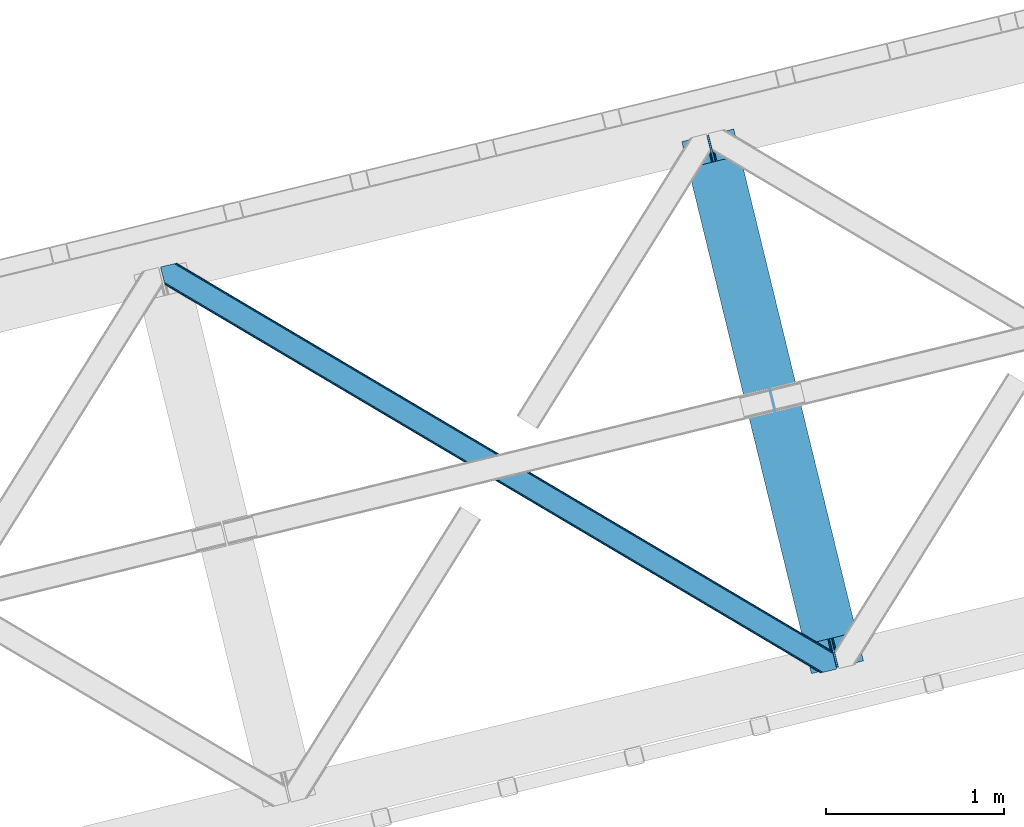
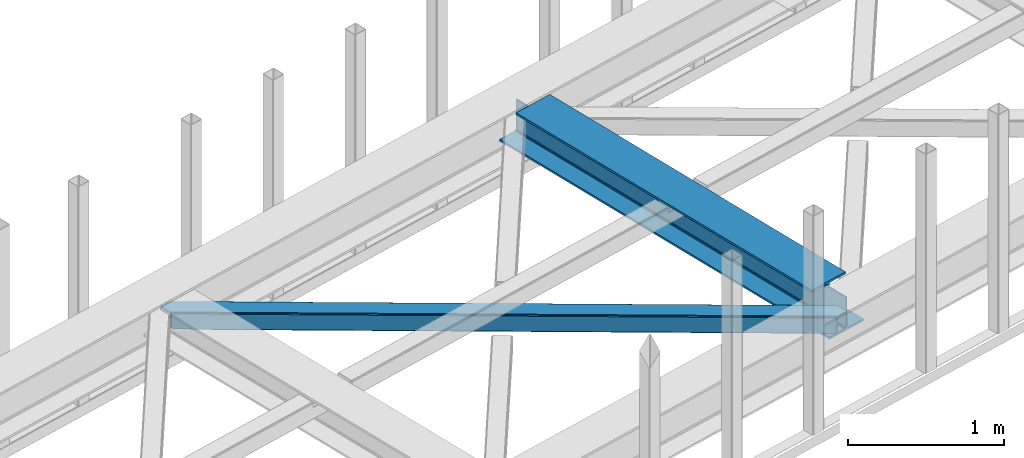
# One storey, part 41 of 66: 1 beam, 1 member.
"""IFC4 building model written with IfcOpenShell, lengths in millimetres."""

from ifc_helpers import new_model, entity, si_unit, converted_unit, derived_unit, direction, frame, origin, place, context, subcontext, project, spatial, triangles, polygons, material, type_object, element, save


model = new_model("IFC4")

# Units and contexts
model_context = context("Model", 3, precision=0.01, world=origin(), true_north=direction((6.12303176911189e-17, 1.0)))
plan_context = context("Plan", 3, precision=0.01, world=origin(), true_north=direction((6.12303176911189e-17, 1.0)))
body_context = subcontext(model_context, "Body", "Model", "MODEL_VIEW")
ifc_project = project(units=[si_unit("LENGTHUNIT", "METRE", prefix="MILLI"), si_unit("AREAUNIT", "SQUARE_METRE"), si_unit("VOLUMEUNIT", "CUBIC_METRE"), converted_unit("PLANEANGLEUNIT", "DEGREE", entity("IfcRatioMeasure", 0.0174532925199433), si_unit("PLANEANGLEUNIT", "RADIAN"), dimensions=[0, 0, 0, 0, 0, 0, 0]), si_unit("MASSUNIT", "GRAM", prefix="KILO"), derived_unit("MASSDENSITYUNIT", [(si_unit("MASSUNIT", "GRAM", prefix="KILO"), 1), (si_unit("LENGTHUNIT", "METRE"), -3)]), derived_unit("MOMENTOFINERTIAUNIT", [(si_unit("LENGTHUNIT", "METRE"), 4)]), si_unit("TIMEUNIT", "SECOND"), si_unit("FREQUENCYUNIT", "HERTZ"), si_unit("THERMODYNAMICTEMPERATUREUNIT", "DEGREE_CELSIUS"), derived_unit("THERMALTRANSMITTANCEUNIT", [(si_unit("MASSUNIT", "GRAM", prefix="KILO"), 1), (si_unit("THERMODYNAMICTEMPERATUREUNIT", "KELVIN"), -1), (si_unit("TIMEUNIT", "SECOND"), -3)]), derived_unit("VOLUMETRICFLOWRATEUNIT", [(si_unit("LENGTHUNIT", "METRE"), 3), (si_unit("TIMEUNIT", "SECOND"), -1)]), derived_unit("MASSFLOWRATEUNIT", [(si_unit("MASSUNIT", "GRAM", prefix="KILO"), 1), (si_unit("TIMEUNIT", "SECOND"), -1)]), derived_unit("ROTATIONALFREQUENCYUNIT", [(si_unit("TIMEUNIT", "SECOND"), -1)]), si_unit("ELECTRICCURRENTUNIT", "AMPERE"), si_unit("ELECTRICVOLTAGEUNIT", "VOLT"), si_unit("POWERUNIT", "WATT"), si_unit("FORCEUNIT", "NEWTON", prefix="KILO"), si_unit("ILLUMINANCEUNIT", "LUX"), si_unit("LUMINOUSFLUXUNIT", "LUMEN"), si_unit("LUMINOUSINTENSITYUNIT", "CANDELA"), derived_unit("USERDEFINED", [(si_unit("MASSUNIT", "GRAM", prefix="KILO"), -1), (si_unit("LENGTHUNIT", "METRE"), -2), (si_unit("TIMEUNIT", "SECOND"), 3), (si_unit("LUMINOUSFLUXUNIT", "LUMEN"), 1)]), derived_unit("LINEARVELOCITYUNIT", [(si_unit("LENGTHUNIT", "METRE"), 1), (si_unit("TIMEUNIT", "SECOND"), -1)]), si_unit("PRESSUREUNIT", "PASCAL"), derived_unit("USERDEFINED", [(si_unit("LENGTHUNIT", "METRE"), -2), (si_unit("MASSUNIT", "GRAM", prefix="KILO"), 1), (si_unit("TIMEUNIT", "SECOND"), -2)]), derived_unit("LINEARFORCEUNIT", [(si_unit("MASSUNIT", "GRAM", prefix="KILO"), 1), (si_unit("LENGTHUNIT", "METRE"), 1), (si_unit("TIMEUNIT", "SECOND"), -2), (si_unit("LENGTHUNIT", "METRE"), -1)]), derived_unit("PLANARFORCEUNIT", [(si_unit("MASSUNIT", "GRAM", prefix="KILO"), 1), (si_unit("LENGTHUNIT", "METRE"), 1), (si_unit("TIMEUNIT", "SECOND"), -2), (si_unit("LENGTHUNIT", "METRE"), -2)])], contexts=[model_context, plan_context])

# Site, building, storey
site_placement = place(None, origin())
site = spatial("IfcSite", under=ifc_project, at=site_placement, CompositionType="ELEMENT")
building_placement = place(site_placement, origin())
building = spatial("IfcBuilding", under=site, at=building_placement, CompositionType="ELEMENT")
storey_placement = place(building_placement, frame((0.0, 0.0, 19800.0)))
storey = spatial("IfcBuildingStorey", under=building, at=storey_placement, Name="06", CompositionType="ELEMENT", Elevation=19800.0)

# Beam
ifc_material = material(Name="Metal painted (White)")
beam_type = type_object("IfcBeamType", PredefinedType="BEAM")
beam_placement = place(storey_placement, frame((-24164.82, 11904.5, 3807.02)))
element("IfcBeam", 1, at=beam_placement, inside=storey, type_object=beam_type, material=ifc_material, ObjectType="Steel Beam", PredefinedType="BEAM", context=body_context, shape_type="Tessellation", body=[
    polygons([(1018.16648378329, 71.0478278971021, 15.5000000000008), (1018.16648378329, 71.0478278971, 0.0), (291.465617442446, 3052.25531830421, 0.0), (291.465617442446, 3052.25531830421, 15.5000000000008), (894.779372399325, 40.970914087327, 15.5000000000008), (168.078506058478, 3022.17840449444, 15.5000000000008), (888.087028625371, 39.3395844888221, 16.8701684147984), (161.38616228452, 3020.54707489593, 16.8701684147984), (882.413533524746, 37.9566100336519, 20.7720779386478), (155.712667183895, 3019.16410044076, 20.7720779386478), (878.622625296176, 37.0325360459184, 26.6116982174338), (151.921758955325, 3018.24002645303, 26.6116982174338), (877.291435352779, 36.7080444135007, 33.500000000001), (150.590569011932, 3017.91553482061, 33.500000000001), (140.875048430518, 3015.54727389071, 33.500000000001), (140.875048430514, 3015.54727389071, 259.000000000002), (150.590569011932, 3017.91553482061, 259.000000000002), (0.0, 2981.20749040711, 0.0), (4.33146851719357e-12, 2981.20749040711, 15.4999999999965), (123.387111383972, 3011.28440421689, 15.5000000000008), (130.079455157926, 3012.91573381539, 16.8701684147984), (135.752950258551, 3014.29870827056, 20.7720779386434), (139.543858487122, 3015.22278225829, 26.6116982174294), (877.291435352779, 36.7080444135007, 259.000000000002), (867.575914771365, 34.3397834835992, 259.000000000002), (867.575914771365, 34.3397834835992, 33.500000000001), (866.244724827968, 34.0152918511837, 26.6116982174294), (862.453816599397, 33.0912178634502, 20.7720779386434), (856.780321498777, 31.7082434082778, 16.8701684147984), (850.087977724819, 30.0769138097708, 15.5000000000008), (726.700866340851, 0.0, 15.4999999999965), (726.700866340851, 0.0, 0.0), (838.124523615916, 197.385937999183, 259.069791973884), (186.469722099967, 2870.72539801218, 259.000000000002), (186.69311520182, 2869.80895360721, 259.617303331124), (186.70550404545, 2869.75812937344, 266.500003008253), (837.979344808143, 197.981416001704, 266.500002998871), (837.979694928899, 197.97997969697, 260.000004007589), (828.499586345872, 194.645865944434, 259.006343171919), (828.276216326107, 195.562317481914, 259.617303331124), (828.263827482477, 195.613141715687, 266.500003008253), (176.98998671978, 2867.38985508742, 266.500002998871), (176.989636599032, 2867.39129139215, 260.000004007589), (176.844830940687, 2867.98534020594, 259.07612046749), (176.754201518552, 2868.35713708228, 259.000000000002), (839.31083267807, 198.30468544639, 273.388305639783), (843.101109266757, 199.231350618303, 279.227924098781), (848.774180214296, 200.616065081981, 283.129832400615), (855.46637189543, 202.248018612794, 284.500000377228), (978.853400583269, 232.325271667903, 284.500000138971), (978.851730776613, 232.332121736637, 299.999995328161), (687.386308679343, 161.283492472596, 299.999995890962), (687.387978485999, 161.276642403863, 284.500000701776), (810.775007173847, 191.353895458974, 284.500000463519), (817.467494069986, 192.984637925553, 283.129832461069), (823.141405718746, 194.365903570079, 279.227924137322), (826.932940505738, 195.287407219375, 273.388305663684), (175.658498849857, 2867.06658564273, 273.388305639788), (171.868222261165, 2866.13992047082, 279.227924098781), (166.195151313635, 2864.75520600714, 283.129832400619), (159.502959632502, 2863.12325247633, 284.500000377228), (36.1159309446533, 2833.04599942122, 284.500000138971), (36.1176007513094, 2833.03914935249, 299.999995328161), (327.58302284858, 2904.08777861653, 299.999995890962), (327.581353041924, 2904.09462868526, 284.500000701776), (204.194324354084, 2874.01737563015, 284.500000463519), (197.501837457945, 2872.38663316357, 283.129832461065), (191.827925809176, 2871.00536751904, 279.227924137322), (188.036391022189, 2870.08386386975, 273.388305663684)], [[[1, 2, 3, 4]], [[5, 1, 4, 6]], [[7, 5, 6, 8]], [[9, 7, 8, 10]], [[11, 9, 10, 12]], [[13, 11, 12, 14]], [[15, 16, 17, 14, 12, 10, 8, 6, 4, 3, 18, 19, 20, 21, 22, 23]], [[13, 24, 25, 26, 27, 28, 29, 30, 31, 32, 2, 1, 5, 7, 9, 11]], [[2, 32, 18, 3]], [[32, 31, 19, 18]], [[31, 30, 20, 19]], [[27, 26, 15, 23]], [[28, 27, 23, 22]], [[29, 28, 22, 21]], [[30, 29, 21, 20]], [[33, 24, 13, 14, 17, 34, 35, 36, 37, 38]], [[25, 39, 40, 41, 42, 43, 44, 16, 15, 26]], [[39, 25, 24, 33]], [[45, 34, 17, 16]], [[41, 40, 38, 37, 46, 47, 48, 49, 50, 51, 52, 53, 54, 55, 56, 57]], [[42, 58, 59, 60, 61, 62, 63, 64, 65, 66, 67, 68, 69, 36, 35, 43]], [[46, 37, 36, 69]], [[47, 46, 69, 68]], [[48, 47, 68, 67]], [[49, 48, 67, 66]], [[50, 49, 66, 65]], [[51, 50, 65, 64]], [[52, 51, 64, 63]], [[53, 52, 63, 62]], [[54, 53, 62, 61]], [[55, 54, 61, 60]], [[56, 55, 60, 59]], [[57, 56, 59, 58]], [[41, 57, 58, 42]]], closed=False),
])

# Member
member_type = type_object("IfcMemberType", PredefinedType="BRACE")
member_placement = place(storey_placement, frame((-27085.5, 11907.55, 3823.0)))
element("IfcMember", 2, at=member_placement, inside=storey, type_object=member_type, ObjectType="Steel Horizontal Brace", PredefinedType="BRACE", context=body_context, shape_type="Tessellation", body=[
    triangles([(3167.12993774414, 476.930191040039, 17.5012573242202), (3764.84926757813, 123.064581298828, 122.499499511719), (3764.84926757813, 123.064581298828, 17.5012573242202), (2547.3375366211, 843.862445068358, 17.5012573242202), (1927.54513549805, 1210.79469909668, 17.5012573242202), (91.5037170410178, 2297.77602539063, 122.499499511719), (687.960333251955, 1944.65804443359, 17.5012573242202), (91.5037170410178, 2297.77602539063, 17.5012573242202), (1307.752734375, 1577.72579040527, 17.5012573242202), (3770.64193725586, 99.297427368163, 140.00075683594), (3768.42579345703, 108.393383789062, 138.668280029298), (76.4813781738303, 2294.11345825195, 138.668280029298), (67.1679931640647, 2291.8438293457, 140.00075683594), (3766.54683837891, 116.103378295898, 134.87548828125), (84.3762451171897, 2296.03775939941, 134.87548828125), (3765.29110107422, 121.255389404296, 129.196765136719), (89.6503417968779, 2297.32372741699, 129.196765136719), (3722.24256591797, 5.93103332519422, 140.00075683594), (18.7686218261733, 2198.47743530273, 140.00075683594), (3789.41055908203, 22.3044525146488, 140.00075683594), (0.0, 2275.47041015625, 140.00075683594), (3697.90916748047, 0.0, 122.499499511719), (3699.76254272461, 0.451135253906614, 129.196765136719), (24.1194580078154, 2176.5194732666, 129.196765136719), (24.5612915039092, 2174.71028137207, 122.499499511719), (3705.03431396485, 1.73710327148365, 134.87548828125), (22.8637207031279, 2181.671484375, 134.87548828125), (3712.92918090821, 3.66140441894458, 138.668280029298), (20.9847656250022, 2189.38147888184, 138.668280029298), (1862.08401489258, 1086.85342712402, 17.5012573242202), (2481.94152832031, 719.882803344726, 17.5012573242202), (3101.79904174805, 352.91217956543, 17.5012573242202), (3697.90916748047, 0.0, 17.5012573242202), (1242.22650146484, 1453.82405090332, 17.5012573242202), (622.371313476564, 1820.79467468262, 17.5012573242202), (24.5612915039092, 2174.71028137207, 17.5012573242202), (74.641955566407, 2293.66581115723, 127.873590087893), (66.7494140625022, 2291.74151000977, 131.668707275392), (79.9183776855498, 2294.9517791748, 122.197192382813), (57.4360290527366, 2289.47071838379, 133.001184082033), (0.0, 2275.47041015625, 133.001184082033), (81.7694274902351, 2295.40291442871, 115.499926757813), (81.7694274902351, 2295.40291442871, 24.5008300781265), (79.9183776855498, 2294.9517791748, 17.8035644531265), (89.5619750976584, 2297.30279846191, 10.8156188964858), (89.4712829589844, 2297.27954406738, 10.4993591308594), (74.1164062500029, 2293.53674926758, 12.4271484375022), (72.035137939456, 2293.0298034668, 10.4993591308594), (1922.19429931641, 1205.8275604248, 24.5008300781265), (3767.16540527344, 113.558184814452, 115.499926757813), (2545.11209106445, 837.045419311524, 24.5008300781265), (3168.02755737305, 468.263278198241, 24.5008300781265), (3767.16540527344, 113.558184814452, 24.5008300781265), (1299.27650756836, 1574.60853881836, 24.5008300781265), (676.361041259766, 1943.39067993164, 24.5008300781265), (3767.60723876953, 111.748992919922, 122.197192382813), (3768.86297607422, 106.596981811523, 127.873590087893), (3770.74193115234, 98.8858245849606, 131.668707275392), (3772.96040039063, 89.7910308837891, 133.001184082033), (3767.69560546875, 111.385061645507, 17.8686767578147), (3767.80490112305, 110.943228149414, 16.5199218750022), (3764.85856933594, 123.027374267578, 16.5199218750022), (3789.41055908203, 22.3044525146488, 133.001184082033), (3731.9745300293, 8.30298156738172, 133.001184082033), (16.4501586914084, 2207.98383178711, 133.001184082033), (162.736578369142, 2253.90428466797, 10.4993591308594), (166.88748779297, 2236.87509155273, 10.4993591308594), (3722.66347045899, 6.03451538085938, 131.668707275392), (18.6686279296882, 2198.88903808594, 131.668707275392), (3714.76860351563, 4.10905151367115, 127.873590087893), (20.547583007814, 2191.17788085938, 127.873590087893), (3709.49450683594, 2.82424621581958, 122.197192382813), (21.8033203125015, 2186.02586975098, 122.197192382813), (3707.64345703125, 2.3719482421875, 115.499926757813), (22.2451538085952, 2184.21667785644, 115.499926757813), (3114.18665771485, 353.712130737304, 24.5008300781265), (3707.64345703125, 2.3719482421875, 24.5008300781265), (2491.1200378418, 722.582638549804, 24.5008300781265), (1868.05341796875, 1091.4531463623, 24.5008300781265), (621.920178222659, 1829.19532470703, 24.5008300781265), (22.2451538085952, 2184.21667785644, 24.5008300781265), (1244.98679809571, 1460.32481689453, 24.5008300781265), (3709.49450683594, 2.82424621581958, 17.8035644531265), (3700.13461303711, 0.541827392577034, 10.8691040039084), (3700.58574829102, 0.652285766600471, 9.52034912109593), (3714.76860351563, 4.10905151367115, 12.1248413085959), (3719.39622802734, 5.23688964843677, 9.52034912109593), (21.7823913574248, 2186.11191101074, 17.817517089843), (21.7614624023445, 2186.20144042969, 17.5012573242202), (32.1375732421875, 2171.84650268555, 10.8179443359368), (28.3494323730483, 2188.73965759277, 10.4993591308594), (27.014630126956, 2187.35137023926, 12.1248413085959), (32.5003417968765, 2171.71046447754, 10.4993591308594), (203.966619873048, 2084.76809692383, 10.4993591308594), (208.117529296876, 2067.73890380859, 10.4993591308594), (164.09696044922, 2252.54739074707, 9.49942016601563), (168.582733154297, 2234.14386291504, 9.49942016601563), (168.166479492189, 2234.81707763672, 9.74591674804833), (163.771398925783, 2252.87527770996, 9.74126586914281), (167.736273193361, 2235.51005859375, 9.9993896484375), (163.417932128908, 2253.22525634766, 9.9993896484375), (167.306066894533, 2236.20187683105, 10.2528625488303), (163.066790771485, 2253.57639770508, 10.2598388671868), (209.161651611328, 2067.67146606445, 9.49942016601563), (209.136071777346, 2067.46682739258, 9.88311767578125), (204.680529785157, 2085.44247436523, 9.8528869628899), (208.803533935548, 2067.5551940918, 10.0831054687515), (204.685180664063, 2084.81111755371, 10.2063537597678), (208.450067138674, 2067.65053710938, 10.2993713378928), (204.324737548828, 2084.78902587891, 10.3528564453118), (204.675878906251, 2086.07383117676, 9.49942016601563), (3763.57725219727, 109.725860595703, 12.1248413085959), (3758.56825561524, 124.970278930663, 10.8714294433594), (3757.06602172852, 125.435366821288, 9.52034912109593), (3761.54481811524, 107.063232421875, 9.52034912109593), (3585.92530517578, 211.033630371094, 9.52034912109593), (3581.44650878906, 229.405764770507, 9.52034912109593), (3585.50672607422, 211.133624267577, 9.44360961914208), (3581.04885864258, 229.553430175782, 9.37384643554833), (3580.64888305664, 229.701095581055, 9.22734375000073), (3580.53726196289, 229.532501220703, 8.87387695312646), (3585.4578918457, 210.476687622069, 9.13897705078125), (3580.42796630859, 229.365069580077, 8.52041015625218), (3585.40673217774, 209.805798339843, 8.82736816406396), (3585.35557250977, 209.14769897461, 8.52041015625218), (3164.51614379883, 472.51883239746, 5.12526855468968), (3581.30465698242, 225.771102905273, 5.12526855468968), (3166.44858398438, 475.783749389648, 10.8039916992202), (687.281304931643, 1943.5116027832, 10.8039916992202), (685.348864746094, 1940.24784851074, 5.12526855468968), (165.152709960938, 2248.2150970459, 5.12526855468968), (682.456018066408, 1935.36210021973, 1.33247680664135), (167.031665039063, 2240.50510253906, 1.33247680664135), (679.044598388675, 1929.59966125488, 0.0), (169.250134277347, 2231.40914611816, 0.0), (3583.18361206055, 218.061108398437, 1.33247680664135), (3585.39975585938, 208.965151977538, 0.0), (3158.21187744141, 461.870645141602, 0.0), (3161.6256225586, 467.634246826172, 1.33247680664135), (2546.65618286133, 842.716003417969, 10.8039916992202), (1926.86610717774, 1209.64825744629, 10.8039916992202), (1307.07370605469, 1576.58051147461, 10.8039916992202), (2544.72606811524, 839.452249145508, 5.12526855468968), (1924.93366699219, 1206.3833404541, 5.12526855468968), (1305.14126586914, 1573.31559448242, 5.12526855468968), (2541.83322143555, 834.566500854491, 1.33247680664135), (1922.0408203125, 1201.49875488281, 1.33247680664135), (1302.24841918945, 1568.42984619141, 1.33247680664135), (2538.41947631836, 828.802899169921, 0.0), (1918.62940063477, 1195.73515319824, 0.0), (1298.83699951172, 1562.66740722656, 0.0), (3620.16042480469, 66.3657165527347, 0.0), (3110.71245117188, 367.97056274414, 0.0), (2490.85493774414, 734.941186523438, 0.0), (1870.99974975586, 1101.91181030273, 0.0), (631.284722900393, 1835.85305786133, 0.0), (1251.14223632813, 1468.88243408203, 0.0), (204.010803222656, 2088.80854797363, 0.0), (3167.34852905274, 467.116836547852, 17.8035644531265), (3165.41608886719, 463.851919555664, 12.1248413085959), (673.749572753906, 1938.98048400879, 12.1248413085959), (675.682012939455, 1942.24423828125, 17.8035644531265), (670.85672607422, 1934.09473571777, 8.3320495605476), (169.398962402345, 2230.80104370117, 8.81806640624927), (171.566271972657, 2221.90274963379, 6.99957275390625), (3159.11182250977, 453.203732299804, 6.99957275390625), (3587.71821899414, 199.458755493164, 6.99957275390625), (3585.50905151367, 208.524481201172, 8.42274169921802), (3162.5232421875, 458.967333984374, 8.3320495605476), (667.445306396487, 1928.33229675293, 6.99957275390625), (2539.60777587891, 827.749475097657, 8.3320495605476), (2536.19403076172, 821.985873413085, 6.99957275390625), (1916.68998413086, 1196.53161621094, 8.3320495605476), (1913.27856445313, 1190.76801452637, 6.99957275390625), (1293.77451782227, 1565.31259460449, 8.3320495605476), (1290.36077270508, 1559.55015563965, 6.99957275390625), (2542.49829711914, 832.634060668945, 12.1248413085959), (1919.58283081055, 1201.41620178223, 12.1248413085959), (1296.66736450195, 1570.19834289551, 12.1248413085959), (2544.43073730469, 835.898977661132, 17.8035644531265), (1921.51294555664, 1204.67995605469, 17.8035644531265), (1298.5998046875, 1573.46325988769, 17.8035644531265), (201.692340087891, 2098.31610717773, 6.99957275390625), (203.861975097658, 2089.41665039063, 8.81806640624927), (206.226947021485, 2079.71375427246, 1.33247680664135), (208.105902099611, 2072.00375976562, 5.12526855468968), (2500.03577270508, 737.642184448241, 6.99957275390625), (3123.10239257813, 368.771676635743, 6.99957275390625), (1876.96915283203, 1106.51269226074, 6.99957275390625), (3617.84428710938, 75.8721130371086, 6.99957275390625), (630.835913085939, 1844.25487060547, 6.99957275390625), (1253.90253295899, 1475.38320007324, 6.99957275390625), (3119.68864746094, 363.008074951171, 8.3320495605476), (3620.56272583008, 65.0402160644535, 8.90410766601781), (3620.2046081543, 66.183169555663, 8.52041015625218), (3116.7981262207, 358.123489379883, 12.1248413085959), (3621.05339355469, 64.3216552734375, 9.1087463378899), (3621.55103759766, 63.5914672851559, 9.31571044922021), (3622.04170532227, 62.8729064941399, 9.52034912109593), (3620.05345458984, 66.8063873291012, 8.42274169921802), (624.529321289065, 1833.60552062988, 12.1248413085959), (627.422167968751, 1838.4912689209, 8.3320495605476), (622.596881103516, 1830.34176635742, 17.8035644531265), (3114.86568603516, 354.858572387695, 17.8035644531265), (2491.79906616211, 723.729080200195, 17.8035644531265), (1868.73244628906, 1092.60075073242, 17.8035644531265), (1245.66582641602, 1461.47125854492, 17.8035644531265), (2493.73150634766, 726.993997192383, 12.1248413085959), (1870.66256103516, 1095.86450500488, 12.1248413085959), (1247.59826660156, 1464.73501281738, 12.1248413085959), (2496.62435302735, 731.879745483398, 8.3320495605476), (1873.55540771484, 1100.7502532959, 8.3320495605476), (1250.49111328125, 1469.6207611084, 8.3320495605476), (3102.47574462891, 354.057458496094, 10.8039916992202), (624.980456542969, 1825.20487060547, 5.12526855468968), (623.048016357425, 1821.94111633301, 10.8039916992202), (3626.52050170899, 44.5007720947269, 9.52034912109593), (3104.40818481446, 357.32237548828, 5.12526855468968), (3624.2578491211, 49.5597656249993, 5.12526855468968), (3625.13453979492, 45.9657989501957, 8.52041015625218), (3625.82752075195, 45.2332855224613, 9.02037963867406), (3622.37889404297, 57.2697601318359, 1.33247680664135), (3107.30103149414, 362.208123779297, 1.33247680664135), (627.873303222659, 1830.09061889648, 1.33247680664135), (2487.44351806641, 729.178747558593, 1.33247680664135), (1867.58833007813, 1096.14937133789, 1.33247680664135), (1247.73081665039, 1463.11999511719, 1.33247680664135), (2484.55299682617, 724.292999267578, 5.12526855468968), (1864.69548339844, 1091.26362304687, 5.12526855468968), (1244.8379699707, 1458.23424682617, 5.12526855468968), (2482.61823120117, 721.02808227539, 10.8039916992202), (1862.76304321289, 1087.99870605469, 10.8039916992202), (1242.90552978516, 1454.96932983398, 10.8039916992202)], [[1, 2, 3], [2, 1, 4], [2, 5, 6], [5, 2, 4], [7, 8, 6], [9, 6, 5], [6, 9, 7], [10, 11, 12], [12, 13, 10], [11, 14, 15], [15, 12, 11], [14, 16, 17], [17, 15, 14], [16, 2, 6], [6, 17, 16], [18, 10, 19], [18, 20, 10], [13, 19, 10], [21, 19, 13], [22, 23, 24], [24, 25, 22], [23, 26, 27], [27, 24, 23], [26, 28, 29], [29, 27, 26], [28, 18, 19], [19, 29, 28], [30, 22, 25], [22, 31, 32], [30, 31, 22], [32, 33, 22], [34, 25, 35], [25, 34, 30], [36, 35, 25], [37, 38, 12], [15, 37, 12], [15, 17, 39], [37, 15, 39], [39, 17, 6], [38, 13, 12], [21, 40, 41], [21, 13, 40], [38, 40, 13], [39, 6, 42], [43, 8, 44], [6, 43, 42], [8, 45, 44], [6, 8, 43], [46, 44, 45], [46, 47, 44], [46, 48, 47], [49, 50, 42], [50, 51, 52], [49, 51, 50], [52, 53, 50], [54, 42, 55], [42, 54, 49], [43, 55, 42], [50, 56, 42], [39, 42, 56], [56, 57, 39], [37, 39, 57], [57, 58, 37], [38, 37, 58], [58, 59, 38], [40, 38, 59], [57, 14, 11], [59, 58, 10], [58, 57, 11], [60, 61, 62], [63, 59, 20], [10, 20, 59], [58, 11, 10], [60, 3, 53], [2, 50, 53], [53, 3, 2], [60, 62, 3], [2, 56, 50], [56, 14, 57], [14, 56, 16], [2, 16, 56], [59, 64, 65], [64, 59, 63], [65, 40, 59], [41, 40, 65], [66, 67, 46], [48, 46, 67], [64, 68, 65], [69, 65, 68], [68, 70, 69], [71, 69, 70], [70, 72, 71], [73, 71, 72], [72, 74, 73], [75, 73, 74], [76, 74, 77], [74, 76, 78], [74, 79, 75], [79, 74, 78], [80, 81, 75], [82, 75, 79], [75, 82, 80], [70, 68, 28], [26, 70, 28], [26, 23, 72], [70, 26, 72], [72, 23, 22], [68, 18, 28], [20, 64, 63], [20, 18, 64], [68, 64, 18], [72, 22, 74], [77, 33, 83], [22, 77, 74], [33, 84, 83], [22, 33, 77], [85, 83, 84], [86, 83, 85], [87, 86, 85], [73, 75, 25], [25, 24, 73], [27, 73, 24], [73, 27, 71], [25, 81, 36], [88, 89, 36], [36, 81, 88], [75, 81, 25], [69, 29, 19], [21, 65, 19], [41, 65, 21], [69, 71, 29], [29, 71, 27], [65, 69, 19], [90, 91, 92], [90, 93, 91], [92, 36, 90], [89, 36, 92], [94, 95, 93], [93, 91, 94], [96, 97, 98], [98, 99, 96], [99, 98, 100], [100, 101, 99], [101, 100, 102], [102, 103, 101], [103, 102, 67], [67, 66, 103], [104, 105, 106], [105, 107, 108], [108, 107, 109], [110, 109, 95], [95, 94, 110], [109, 110, 108], [108, 106, 105], [106, 111, 104], [62, 112, 113], [112, 62, 61], [112, 114, 113], [112, 115, 114], [114, 115, 116], [116, 117, 114], [118, 119, 117], [120, 119, 118], [121, 120, 122], [123, 121, 124], [124, 125, 123], [122, 124, 121], [118, 122, 120], [117, 116, 118], [1, 3, 113], [3, 62, 113], [120, 121, 126], [123, 126, 121], [123, 127, 126], [128, 113, 117], [117, 126, 128], [117, 119, 126], [120, 126, 119], [113, 114, 117], [45, 129, 66], [129, 130, 131], [131, 96, 129], [129, 99, 101], [99, 129, 96], [129, 103, 66], [103, 129, 101], [129, 45, 8], [8, 7, 129], [66, 46, 45], [130, 132, 133], [133, 131, 130], [132, 134, 135], [135, 133, 132], [136, 137, 138], [138, 139, 136], [127, 136, 139], [139, 126, 127], [113, 128, 1], [1, 128, 140], [140, 4, 1], [4, 140, 141], [141, 5, 4], [5, 141, 142], [142, 9, 5], [9, 142, 129], [129, 7, 9], [128, 126, 143], [143, 140, 128], [140, 143, 141], [144, 141, 143], [141, 144, 142], [145, 142, 144], [142, 145, 129], [130, 129, 145], [126, 139, 146], [146, 143, 126], [143, 146, 147], [147, 144, 143], [144, 147, 148], [148, 145, 144], [145, 148, 132], [132, 130, 145], [139, 138, 146], [149, 146, 138], [146, 149, 147], [150, 147, 149], [147, 150, 148], [151, 148, 150], [148, 151, 132], [134, 132, 151], [137, 152, 153], [138, 153, 154], [153, 138, 137], [149, 155, 150], [154, 149, 138], [149, 154, 155], [156, 134, 151], [150, 157, 151], [157, 150, 155], [157, 156, 151], [158, 134, 156], [135, 134, 158], [159, 160, 112], [112, 61, 159], [159, 60, 53], [161, 162, 44], [98, 163, 100], [98, 97, 163], [163, 102, 100], [163, 67, 102], [97, 164, 163], [161, 47, 67], [67, 163, 161], [47, 48, 67], [163, 164, 165], [166, 167, 168], [160, 118, 116], [116, 112, 160], [116, 115, 112], [169, 168, 125], [125, 160, 169], [124, 122, 160], [122, 118, 160], [160, 125, 124], [168, 169, 166], [165, 170, 163], [44, 47, 161], [162, 55, 43], [43, 44, 162], [53, 52, 159], [61, 60, 159], [166, 169, 171], [171, 172, 166], [172, 171, 173], [173, 174, 172], [174, 173, 175], [175, 176, 174], [176, 175, 163], [163, 170, 176], [169, 160, 171], [177, 171, 160], [171, 177, 173], [178, 173, 177], [173, 178, 175], [179, 175, 178], [175, 179, 163], [161, 163, 179], [160, 159, 180], [180, 177, 160], [177, 180, 181], [181, 178, 177], [178, 181, 182], [182, 179, 178], [179, 182, 162], [162, 161, 179], [159, 52, 180], [51, 180, 52], [180, 51, 49], [49, 181, 180], [181, 49, 54], [54, 182, 181], [182, 54, 162], [55, 162, 54], [97, 131, 133], [135, 97, 133], [165, 164, 135], [165, 135, 183], [131, 97, 96], [135, 164, 97], [183, 158, 184], [158, 185, 111], [158, 183, 135], [186, 111, 185], [158, 111, 184], [186, 104, 111], [187, 188, 166], [166, 172, 187], [172, 189, 187], [189, 172, 174], [188, 167, 166], [188, 190, 167], [170, 191, 176], [191, 170, 183], [165, 183, 170], [192, 176, 191], [174, 192, 189], [176, 192, 174], [193, 194, 195], [196, 197, 194], [196, 198, 197], [196, 199, 198], [194, 193, 196], [195, 200, 193], [86, 87, 199], [199, 196, 86], [193, 200, 190], [191, 183, 184], [201, 108, 110], [110, 94, 201], [94, 92, 201], [94, 91, 92], [202, 106, 108], [202, 111, 106], [202, 184, 111], [108, 201, 202], [203, 201, 92], [92, 89, 203], [203, 88, 81], [81, 80, 203], [89, 88, 203], [184, 202, 191], [190, 188, 193], [83, 86, 196], [196, 204, 83], [77, 83, 204], [204, 76, 77], [76, 204, 205], [205, 78, 76], [78, 205, 206], [206, 79, 78], [79, 206, 207], [207, 82, 79], [82, 207, 80], [203, 80, 207], [204, 196, 205], [208, 205, 196], [205, 208, 206], [209, 206, 208], [206, 209, 207], [210, 207, 209], [207, 210, 201], [201, 203, 207], [196, 193, 211], [211, 208, 196], [208, 211, 212], [212, 209, 208], [209, 212, 213], [213, 210, 209], [210, 213, 202], [202, 201, 210], [193, 188, 211], [187, 211, 188], [211, 187, 212], [189, 212, 187], [212, 189, 213], [192, 213, 189], [213, 192, 191], [191, 202, 213], [214, 84, 33], [35, 36, 90], [215, 105, 104], [216, 90, 95], [95, 215, 216], [95, 107, 215], [104, 186, 215], [84, 214, 217], [214, 218, 219], [219, 220, 214], [221, 217, 214], [214, 220, 221], [217, 85, 84], [222, 219, 218], [218, 223, 222], [152, 222, 223], [223, 153, 152], [156, 224, 185], [185, 158, 156], [224, 215, 186], [186, 185, 224], [90, 216, 35], [33, 32, 214], [153, 223, 154], [225, 154, 223], [154, 225, 155], [226, 155, 225], [155, 226, 157], [227, 157, 226], [157, 227, 224], [224, 156, 157], [223, 218, 228], [228, 225, 223], [225, 228, 229], [229, 226, 225], [226, 229, 230], [230, 227, 226], [227, 230, 224], [215, 224, 230], [218, 214, 231], [231, 228, 218], [228, 231, 229], [232, 229, 231], [229, 232, 230], [233, 230, 232], [230, 233, 216], [216, 215, 230], [214, 32, 31], [31, 231, 214], [231, 31, 30], [30, 232, 231], [232, 30, 34], [34, 233, 232], [233, 34, 216], [35, 216, 34], [137, 167, 190], [125, 127, 123], [137, 125, 167], [125, 136, 127], [125, 137, 136], [152, 137, 190], [195, 152, 190], [219, 195, 220], [195, 222, 152], [195, 219, 222], [220, 195, 194], [221, 194, 197], [221, 197, 198], [217, 198, 199], [87, 85, 199], [217, 199, 85]]),
])

save(model, "model.ifc")
